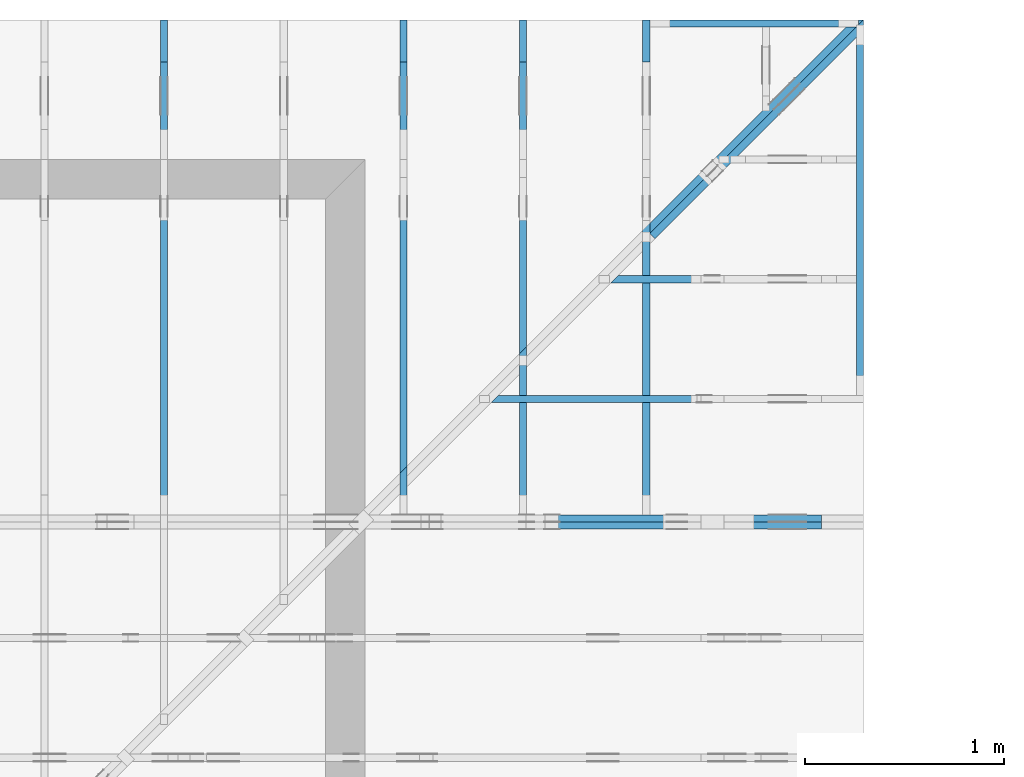
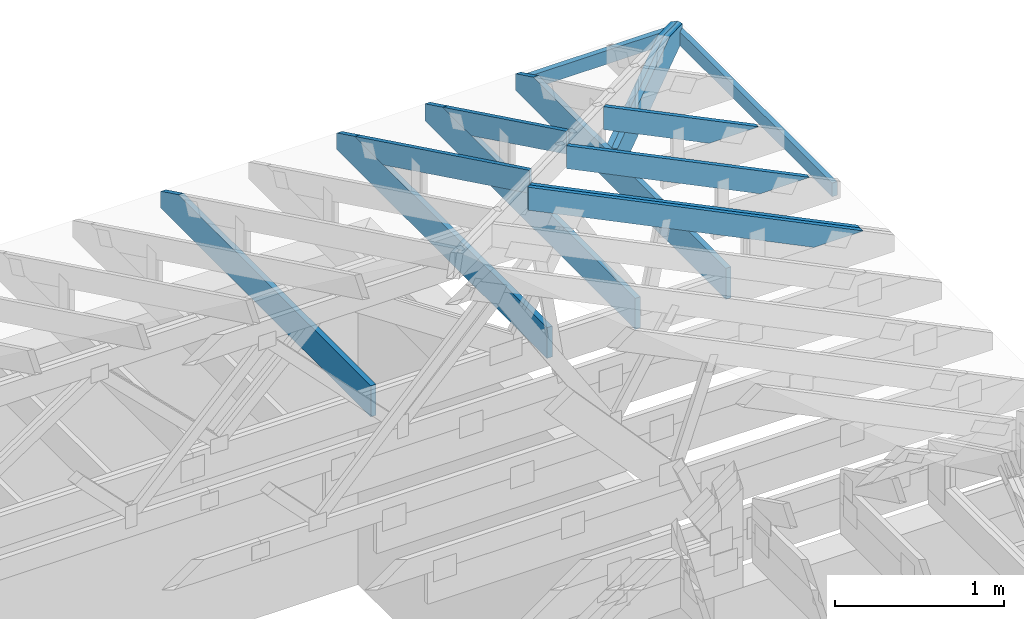
# One storey, part 40 of 159: 14 members, 10 elements without a shape of their own.
"""IFC2X3 building model written with IfcOpenShell, lengths in millimetres."""

from ifc_helpers import new_model, si_unit, frame, origin, origin_with_axes, origin_2d, place, context, project, spatial, faceted_brep, element, aggregate, save


model = new_model("IFC2X3")

# Units and contexts
model_context = context("Model", 3, precision=1e-05, world=origin())
plan_context = context("Plan", 2, precision=1e-05, world=origin_2d())
ifc_project = project(units=[si_unit("LENGTHUNIT", "METRE", prefix="MILLI"), si_unit("AREAUNIT", "SQUARE_METRE"), si_unit("VOLUMEUNIT", "CUBIC_METRE"), si_unit("SOLIDANGLEUNIT", "STERADIAN"), si_unit("PLANEANGLEUNIT", "RADIAN"), si_unit("MASSUNIT", "GRAM"), si_unit("TIMEUNIT", "SECOND"), si_unit("THERMODYNAMICTEMPERATUREUNIT", "DEGREE_CELSIUS"), si_unit("LUMINOUSINTENSITYUNIT", "LUMEN")], contexts=[model_context, plan_context])

# Site, building, storey
site_placement = place(None, origin_with_axes())
site = spatial("IfcSite", under=ifc_project, at=site_placement, CompositionType="ELEMENT")
building_placement = place(site_placement, origin_with_axes())
building = spatial("IfcBuilding", under=site, at=building_placement, Name="Plan 1", CompositionType="ELEMENT")
storey_placement = place(building_placement, origin_with_axes())
storey = spatial("IfcBuildingStorey", under=building, at=storey_placement, Name="Etasje 1", CompositionType="ELEMENT", Elevation=0.0)

# Assembly, members
assembly_1_placement = place(storey_placement, frame((19200.01266310149, 11417.999978540158, 0.0), z_axis=(1.2246063538223773e-16, 1.0, 6.123031769111886e-17), x_axis=(-1.0, 1.2246063538223773e-16, 0.0)))
assembly_1 = element("IfcElementAssembly", 1, at=assembly_1_placement, inside=storey, Name="V9 (1)", AssemblyPlace="FACTORY", PredefinedType="TRUSS")
member_1_placement = place(assembly_1_placement, frame((276.0601842808801, 89.97846073185853, -36.00000021758841), z_axis=(0.0, 0.0, 1.0), x_axis=(0.8987940462991674, 0.4383711467890767, 0.0)))
member_1 = element("IfcMember", 2, at=member_1_placement, Name="V9-O46.2/", context=model_context, shape_type="Brep", body=[
    faceted_brep([(2509.9265675109073, 148.00000083082767, 2.253328602819238e-06), (2469.8729005135738, 147.99999513789197, 35.99999718737763), (2397.6884765625, 3.2118276749315555e-07, 36.000000217588195), (2437.742146505028, -5.684341886080802e-14, -2.2737367544323206e-13), (9.693632841845101e-05, 148.00000032211753, 2.1758840773600238e-07), (9.693632841845101e-05, 148.00000032211753, 36.000000217588415), (2469.8728996707036, 148.0000003221174, 36.000000217588415), (2509.9265686465337, 148.0000003221174, 2.1758840773600238e-07), (5.585594794865756e-05, 148.00000032054504, 2.1758840773600924e-07), (2509.926569527823, 148.00000032054504, 2.1758871510320488e-07), (2437.7421441738193, 3.221430233679712e-07, 2.175887062634543e-07), (303.4451242153232, 3.221430233679712e-07, 2.1758844489608513e-07), (303.44501446892843, 3.2039707775766146e-07, 2.175884077360024e-07), (303.44501446892843, 3.2039707775766146e-07, 36.00000021758841), (4.275579697576859e-05, 148.0000018613371, 36.00000021758841), (4.275579697576859e-05, 148.0000018613371, 2.175884077360024e-07), (2437.7421464196145, 3.211971882968838e-07, 2.175884077360024e-07), (2397.6884774437844, 3.2119719785867186e-07, 36.00000021758841), (303.44502727898976, 3.2119758255224717e-07, 36.00000021758841), (303.44502727898976, 3.2119758034795574e-07, 2.175884077360024e-07), (2469.8729019165044, 148.0000003211826, 36.00000021758841), (0.0, 148.0000003211826, 36.00000021758841), (303.4450683593752, 3.2039704933595203e-07, 36.00000021758841), (2397.6884765625005, 3.2039704933595203e-07, 36.00000021758841)], [[[0, 1, 2, 3]], [[4, 5, 6, 7]], [[8, 9, 10, 11]], [[12, 13, 14, 15]], [[16, 17, 18, 19]], [[20, 21, 22, 23]]]),
])
member_2_placement = place(assembly_1_placement, frame((276.06014875934784, 89.97843985036639, -72.0), z_axis=(0.0, 0.0, 1.0), x_axis=(0.8987940462991674, 0.4383711467890767, 0.0)))
member_2 = element("IfcMember", 3, at=member_2_placement, Name="V9-O46.2/", context=model_context, shape_type="Brep", body=[
    faceted_brep([(2538.248801395678, 148.00000519359992, 10.544184276268652), (2509.926611451075, 147.99999833445304, 35.999996969790345), (2437.742187500001, 3.5177433233002375e-06, 36.00000000000023), (2466.064374499408, 3.2894670312089147e-06, 10.544186846680532), (9.693633353435871e-05, 148.000003518689, 0.0), (9.693633353435871e-05, 148.000003518689, 36.00000000000001), (2509.9266106082086, 148.00000351868886, 36.00000000000001), (2538.2487980319147, 148.00000351868886, 10.544185638427734), (2538.2487980319147, 148.00000351868886, -1.1044052673094165e-29), (2538.2487987942563, 148.00000355018324, 1.0740475886450439e-07), (2538.2487987942563, 148.00000355018324, 10.544185894022071), (2466.064378398536, 9.110662745115405e-06, 10.54418560520537), (2466.064378398536, 9.110662858802243e-06, 4.6991519297989726e-07), (303.4450555493138, 3.516943081649515e-06, 5.4704588450238366e-30), (303.4450555493138, 3.516943081649515e-06, 36.0), (8.383618233409607e-05, 148.0000050578831, 36.0), (8.383618233409607e-05, 148.0000050578831, 1.9992341226455827e-31), (2466.064375670692, 3.5177538410863624e-06, 2.555943297011254e-07), (2466.064375670692, 3.517753841731986e-06, 10.544185894022071), (2437.742188246986, 3.517753848493183e-06, 36.00000025559434), (303.4449909050669, 3.5177542405442695e-06, 36.00000025559434), (303.4449909050669, 3.517754238339978e-06, 2.555943297011254e-07), (2509.926612854004, 148.00000351774383, 36.0), (0.0, 148.00000351774383, 36.0), (303.4450683593751, 3.5169432521797717e-06, 36.0), (2437.7421875, 3.5169432521797717e-06, 36.0), (1.94820292449549e-05, 148.0000035170913, 2.3857816798725143e-21), (2538.248798778904, 148.0000035170913, 3.1083556065666625e-13), (2466.0643734249006, 3.518706989780185e-06, 3.019958100631133e-13), (303.44508784140396, 3.518706989780185e-06, 3.716007826067727e-14)], [[[0, 1, 2, 3]], [[4, 5, 6, 7, 8]], [[9, 10, 11, 12]], [[13, 14, 15, 16]], [[17, 18, 19, 20, 21]], [[22, 23, 24, 25]], [[26, 27, 28, 29]]]),
])
aggregate(assembly_1, [member_1, member_2])

assembly_2_placement = place(storey_placement, frame((19174.556818978774, 13925.455822662876, 2.204291436880279e-15), z_axis=(-0.7071067811865465, 0.7071067811865486, 6.123031769111886e-17), x_axis=(-0.7071067811865486, -0.7071067811865465, 0.0)))
assembly_2 = element("IfcElementAssembly", 4, at=assembly_2_placement, inside=storey, Name="GR3 (58)", AssemblyPlace="FACTORY", PredefinedType="TRUSS")
member_3_placement = place(assembly_2_placement, frame((1514.6091523000334, 223.00000000001435, -36.00000107077109), z_axis=(0.0, 0.0, 1.0), x_axis=(-1.0, 1.2246063538223773e-16, 0.0)))
member_3 = element("IfcMember", 5, at=member_3_placement, Name="GR3-U17.1", context=model_context, shape_type="Brep", body=[
    faceted_brep([(-1.3570674021985078e-14, 1.4076707465682665e-11, 2.1252264003405104e-13), (36.000001068749036, 1.404032445861958e-11, 36.000001070771084), (36.00000106874927, 223.000000000014, 36.00000107077109), (-3.6040238038717733e-16, 223.00000000001404, 3.604023803666417e-16), (1197.9537364203115, 1.4942895894789178e-13, 1.070771091349343e-06), (1197.9537364203115, 1.7561406771667544e-13, 36.00000107077109), (36.00000106874904, 3.890544567905507e-13, 36.00000107077109), (1.0687490430427715e-06, 3.694822223324079e-13, 1.070771091349343e-06), (1514.6091533699246, 223.00000233343388, 1.0506937542231753e-09), (1478.609152300065, 223.00000233343388, 36.00000107080825), (1478.609152300065, 96.79217762640263, 36.00000107080814), (1514.6085005994914, 109.2075972049273, 0.0006527714839421606), (1.070774032996269e-06, 223.00000000001435, 1.070771091349343e-06), (36.00000107077403, 223.00000000001435, 36.00000107077109), (1478.609131930149, 223.00000000001427, 36.00000107077109), (1514.609131930149, 223.00000000001427, 1.070771091349343e-06), (1514.6084997170888, 109.20759731232903, 0.0006536538031554073), (1478.6091537227362, 96.79217811706559, 36.00000134057073), (1197.9537016181357, 6.185791789903305e-07, 36.00000134057072), (1197.9537016181357, 6.185791789903305e-07, 1.0707782109875552e-06), (1478.6091319281243, 223.00000000000034, 36.00000107077109), (36.00000106874927, 223.00000000000034, 36.00000107077109), (36.00000106874904, 1.404032445861958e-11, 36.00000107077109), (1197.9537364203118, 1.404032445861958e-11, 36.00000107077109), (1478.6091319281243, 96.79217529298279, 36.00000107077109), (2.1440658429128234e-05, 223.00000000001435, 1.0707710913493454e-06), (1514.6091523000334, 223.00000000001435, 1.070771276829342e-06), (1514.6084997170667, 109.20759582519531, 1.0707712768292622e-06), (1197.9536957570647, 0.0, 1.0707712380515136e-06), (2.1440658429128234e-05, 0.0, 1.0707710913493454e-06)], [[[0, 1, 2, 3]], [[4, 5, 6, 7]], [[8, 9, 10, 11]], [[12, 13, 14, 15]], [[16, 17, 18, 19]], [[20, 21, 22, 23, 24]], [[25, 26, 27, 28, 29]]]),
])
member_4_placement = place(assembly_2_placement, frame((1514.6091878283771, 223.0000036032329, -72.00000088236348), z_axis=(0.0, 0.0, 1.0), x_axis=(-1.0, 1.2246063538223773e-16, 0.0)))
member_4 = element("IfcMember", 6, at=member_4_placement, Name="GR3-U17.1", context=model_context, shape_type="Brep", body=[
    faceted_brep([(1478.6091869461084, 223.00000509035152, -1.1368683772161603e-13), (1514.6091878283837, 223.00000509035152, 36.000000882368), (1514.6085352454324, 109.20760091554682, 35.99934829941651), (1478.6091869461084, 96.79218133699456, -1.1368683772161603e-13), (5.6969002116602496e-05, 223.00000360321854, 8.823634800592117e-07), (5.6969002116602496e-05, 223.00000360321854, 36.00000088236348), (1514.6091878283771, 223.00000360321846, 36.00000088236348), (1478.6091878283771, 223.00000360321846, 8.823634800592117e-07), (5.6969096476677805e-05, 223.0000036032329, 8.823634800592187e-07), (1478.6091878284715, 223.0000036032329, 8.823636611306324e-07), (1478.6091878284715, 96.79217889618764, 8.823636611306324e-07), (1197.9537312855027, 3.6032188859280723e-06, 8.823636267613868e-07), (5.6969096476677805e-05, 3.6032188859280723e-06, 8.823634800592187e-07), (3.659911749309686e-05, 3.322476146649933e-06, 1.448955373462013e-06), (3.6599117495301154e-05, 3.322476146649933e-06, 36.00000088236348), (3.659911772067366e-05, 223.00000692619702, 36.000002030721966), (3.659911771846937e-05, 223.00000692619702, 2.2173422848936752e-06), (1197.9537353515625, 3.6027671585987974e-06, 8.823634800592117e-07), (1197.9537353515625, 3.602767160803089e-06, 36.00000088236348), (4.049084095856565e-31, 3.6027673808563523e-06, 36.00000088236348), (1.1754943508222875e-38, 3.602767378652061e-06, 8.823634800592117e-07), (1514.608533822824, 109.20760042491952, 35.99934856913106), (1197.953724905109, 0.0, 36.00000088236346), (1197.953724905109, 0.0, 8.823634800592118e-07), (1478.609187828472, 96.79218122965557, 8.823634800592118e-07), (1514.609187828399, 223.00000509035152, 36.00000088236348), (1.473761972192733e-05, 223.00000509035152, 36.00000088236348), (1.473761972192733e-05, 5.0903515216305095e-06, 36.00000088236348), (1197.9537500891822, 5.0903515216305095e-06, 36.00000088236348), (1514.6085352454322, 109.20760091554682, 36.00000088236348)], [[[0, 1, 2, 3]], [[4, 5, 6, 7]], [[8, 9, 10, 11, 12]], [[13, 14, 15, 16]], [[17, 18, 19, 20]], [[21, 22, 23, 24]], [[25, 26, 27, 28, 29]]]),
])
aggregate(assembly_2, [member_3, member_4])

# Assembly, member
assembly_3_placement = place(storey_placement, frame((15675.022261404756, 13899.999978540158, 1.1021457184401395e-15), z_axis=(-1.0, 1.836909530733566e-16, 6.123031769111886e-17), x_axis=(-1.836909530733566e-16, -1.0, 0.0)))
assembly_3 = element("IfcElementAssembly", 7, at=assembly_3_placement, inside=storey, Name="S38 (64)", AssemblyPlace="FACTORY", PredefinedType="TRUSS")
member_5_placement = place(assembly_3_placement, frame((2482.0, 223.00000000093004, -36.0), z_axis=(0.0, 0.0, 1.0), x_axis=(-1.0, 5.665498452323003e-16, 0.0)))
member_5 = element("IfcMember", 8, at=member_5_placement, Name="S38-U12", context=model_context, shape_type="Brep", body=[
    faceted_brep([(2482.0, 223.00000000093144, 36.0), (0.0, 223.00000000093144, 36.0), (0.0, 9.300435976911103e-10, 36.0), (2270.8187103271484, 9.300435976911103e-10, 36.0), (2482.0, 103.00000000093144, 36.0), (0.0, 223.00000000093144, 0.0), (2482.0, 223.00000000093144, 3.0394729701871404e-13), (2482.0, 103.00000000093144, 3.0394729701871404e-13), (2270.8187103271484, 9.300435976911103e-10, 2.7808590210453623e-13), (0.0, 9.300435976911103e-10, 0.0), (1.1389372990643566e-25, 9.300435976911103e-10, -6.97374926519754e-42), (2.204291436994173e-15, 9.300435976911103e-10, 36.0), (2.9513013127233185e-14, 223.00000000093004, 36.0), (2.7308721690352905e-14, 223.00000000093004, -1.672121704838657e-30), (2270.8187043163925, -1.6082071276856806e-13, 9.847103334126301e-30), (2270.8187043163925, -1.5861642133168778e-13, 36.0), (9.029525915557911e-28, 9.300458019825472e-10, 36.0), (0.0, 9.300435976911103e-10, 0.0), (2482.0000000000005, 103.00000000087255, 4.487866375234114e-29), (2482.0000000000005, 103.00000000087255, 36.0), (2270.8187043163925, -6.821210263296962e-13, 36.0), (2270.8187043163925, -6.821210263296962e-13, 3.1532860652502367e-29), (2482.0, 223.00000000093144, 0.0), (2482.0, 223.00000000093144, 36.0), (2482.0, 103.00000000087323, 36.0), (2482.0, 103.00000000087323, 0.0), (0.0, 223.00000000093004, 0.0), (0.0, 223.00000000093004, 36.0), (2482.0, 223.0000000009321, 36.0), (2482.0, 223.0000000009321, 4.1020767071492614e-29)], [[[0, 1, 2, 3, 4]], [[5, 6, 7, 8, 9]], [[10, 11, 12, 13]], [[14, 15, 16, 17]], [[18, 19, 20, 21]], [[22, 23, 24, 25]], [[26, 27, 28, 29]]]),
])
aggregate(assembly_3, [member_5])

# Assembly, members
assembly_4_placement = place(storey_placement, frame((16875.02226140476, 13899.999978540158, 1.1021457184401395e-15), z_axis=(-1.0, 1.836909530733566e-16, 6.123031769111886e-17), x_axis=(-1.836909530733566e-16, -1.0, 0.0)))
assembly_4 = element("IfcElementAssembly", 9, at=assembly_4_placement, inside=storey, Name="S40 (65)", AssemblyPlace="FACTORY", PredefinedType="TRUSS")
member_6_placement = place(assembly_4_placement, frame((276.06016722592847, 89.97845277006275, -36.00000021762676), z_axis=(0.0, 0.0, 1.0), x_axis=(0.8987940462991668, 0.4383711467890777, 0.0)))
member_6 = element("IfcMember", 10, at=member_6_placement, Name="S40-O51", context=model_context, shape_type="Brep", body=[
    faceted_brep([(2295.5059571541397, 147.999994816739, 36.00000324776647), (2223.321533203125, -1.1368683772161603e-13, 36.00000021762639), (2183.267863260632, 3.211325179108826e-07, -4.547473508864641e-13), (2255.4522872116463, 147.99999513787157, 3.030139396287268e-06), (9.6936336831277e-05, 148.00000000095304, 2.1762676283287874e-07), (9.6936336831277e-05, 148.00000000095292, 36.00000021762676), (2295.5059563113364, 148.00000000095278, 36.00000021762676), (2255.4522873355063, 148.0000000009529, 2.1762676283287874e-07), (0.00013801681973291124, 147.99999999934334, 2.1762676283289565e-07), (2255.4522864543196, 147.99999999934334, 2.1762703903699883e-07), (2183.2678611003157, 9.248424248653464e-10, 2.1762703019724822e-07), (303.44508430588246, 9.248424248653464e-10, 2.1762679999295656e-07), (303.4450332880381, 1.1056044968427159e-11, 2.1762676283287874e-07), (303.4450332880381, 1.1056044968427159e-11, 36.00000021762676), (6.157490692970669e-05, 148.00000154095162, 36.00000021762676), (6.157490692970669e-05, 148.0000015409516, 2.1762676283287874e-07), (2223.3215323219515, -1.8504333334278244e-13, 36.00000021762676), (303.4449873695588, 1.6762061898270549e-13, 36.00000021762676), (303.4449873695588, 2.853204142053421e-13, 2.1762676283287874e-07), (2183.2678633461214, -5.99860414918909e-14, 2.1762676283287874e-07), (2295.5059585571285, 148.0000000000001, 36.00000021762676), (0.0, 148.0000000000001, 36.00000021762676), (303.44506835937466, 1.1397105481592007e-11, 36.00000021762676), (2223.3215332031245, 1.1397105481592007e-11, 36.00000021762676)], [[[0, 1, 2, 3]], [[4, 5, 6, 7]], [[8, 9, 10, 11]], [[12, 13, 14, 15]], [[16, 17, 18, 19]], [[20, 21, 22, 23]]]),
])
member_7_placement = place(assembly_4_placement, frame((2482.0, 223.00000000093004, -36.0), z_axis=(0.0, 0.0, 1.0), x_axis=(-1.0, 5.665498452323003e-16, 0.0)))
member_7 = element("IfcMember", 11, at=member_7_placement, Name="S40-U12", context=model_context, shape_type="Brep", body=[
    faceted_brep([(2482.0, 223.00000000093144, 36.0), (0.0, 223.00000000093144, 36.0), (0.0, 9.300435976911103e-10, 36.0), (2270.8187103271484, 9.300435976911103e-10, 36.0), (2482.0, 103.00000000093144, 36.0), (0.0, 223.00000000093144, 0.0), (2482.0, 223.00000000093144, 3.0394729701871404e-13), (2482.0, 103.00000000093144, 3.0394729701871404e-13), (2270.8187103271484, 9.300435976911103e-10, 2.7808590210453623e-13), (0.0, 9.300435976911103e-10, 0.0), (1.1389372990643566e-25, 9.300435976911103e-10, -6.97374926519754e-42), (2.204291436994173e-15, 9.300435976911103e-10, 36.0), (2.9513013127233185e-14, 223.00000000093004, 36.0), (2.7308721690352905e-14, 223.00000000093004, -1.672121704838657e-30), (2270.8187043163925, -1.6082071276856806e-13, 9.847103334126301e-30), (2270.8187043163925, -1.5861642133168778e-13, 36.0), (9.029525915557911e-28, 9.300458019825472e-10, 36.0), (0.0, 9.300435976911103e-10, 0.0), (2482.0000000000005, 103.00000000087255, 4.487866375234114e-29), (2482.0000000000005, 103.00000000087255, 36.0), (2270.8187043163925, -6.821210263296962e-13, 36.0), (2270.8187043163925, -6.821210263296962e-13, 3.1532860652502367e-29), (2482.0, 223.00000000093144, 0.0), (2482.0, 223.00000000093144, 36.0), (2482.0, 103.00000000087323, 36.0), (2482.0, 103.00000000087323, 0.0), (0.0, 223.00000000093004, 0.0), (0.0, 223.00000000093004, 36.0), (2482.0, 223.0000000009321, 36.0), (2482.0, 223.0000000009321, 4.1020767071492614e-29)], [[[0, 1, 2, 3, 4]], [[5, 6, 7, 8, 9]], [[10, 11, 12, 13]], [[14, 15, 16, 17]], [[18, 19, 20, 21]], [[22, 23, 24, 25]], [[26, 27, 28, 29]]]),
])
aggregate(assembly_4, [member_6, member_7])

assembly_5_placement = place(storey_placement, frame((17475.02226140476, 13899.999978540158, 1.1021457184401395e-15), z_axis=(-1.0, 1.836909530733566e-16, 6.123031769111886e-17), x_axis=(-1.836909530733566e-16, -1.0, 0.0)))
assembly_5 = element("IfcElementAssembly", 12, at=assembly_5_placement, inside=storey, Name="S41 (67)", AssemblyPlace="FACTORY", PredefinedType="TRUSS")
member_8_placement = place(assembly_5_placement, frame((276.06017521396706, 89.97845666585107, -36.000000217626834), z_axis=(0.0, 0.0, 1.0), x_axis=(0.898794046299167, 0.4383711467890774, 0.0)))
member_8 = element("IfcMember", 13, at=member_8_placement, Name="S41-O61", context=model_context, shape_type="Brep", body=[
    faceted_brep([(1627.944783981857, 147.9999948174301, 36.00000324776579), (1555.7603600308425, 6.912159733474255e-10, 36.00000021762662), (1515.7066900883492, 3.2182356335397344e-07, -2.2737367544323206e-13), (1587.8911140393639, 147.99999513856272, 3.030139055226755e-06), (8.098980043769188e-05, 147.9999999999703, 2.1762683388715232e-07), (8.098980043769188e-05, 147.99999999997019, 36.00000021762684), (1627.944783138238, 147.9999999999701, 36.00000021762684), (1587.8911141624078, 147.9999999999702, 2.1762683388715232e-07), (0.0, 148.00000000119053, 2.1762683388715232e-07), (1587.89111328125, 148.00000000119053, 2.1762702834130697e-07), (1515.706687927246, 0.0, 2.1762701950155638e-07), (303.445068359375, 0.0, 2.1762687104722818e-07), (303.44502440063553, 2.255262643302558e-10, 2.1762683388715232e-07), (303.44502440063553, 2.255262643302558e-10, 36.000000217626834), (5.2687504208392966e-05, 148.0000015411658, 36.000000217626834), (5.2687504208392966e-05, 148.0000015411658, 2.1762683388715232e-07), (1555.7603591496627, 6.763316512911086e-10, 36.000000217626834), (303.4449714238324, 6.765616902982284e-10, 36.000000217626834), (303.4449714238324, 6.76679390093451e-10, 2.1762683388715232e-07), (1515.7066901738324, 6.764567085829595e-10, 2.1762683388715232e-07), (1627.9447853848462, 148.00000000069167, 36.000000217626834), (0.00010612459209369263, 148.00000000069167, 36.000000217626834), (303.4450524136548, 2.2563995116797742e-10, 36.000000217626834), (1555.7603600308425, 2.2563995116797742e-10, 36.000000217626834)], [[[0, 1, 2, 3]], [[4, 5, 6, 7]], [[8, 9, 10, 11]], [[12, 13, 14, 15]], [[16, 17, 18, 19]], [[20, 21, 22, 23]]]),
])
member_9_placement = place(assembly_5_placement, frame((2482.0, 223.00000000093004, -36.0), z_axis=(0.0, 0.0, 1.0), x_axis=(-1.0, 5.665498452323003e-16, 0.0)))
member_9 = element("IfcMember", 14, at=member_9_placement, Name="S41-U12", context=model_context, shape_type="Brep", body=[
    faceted_brep([(2482.0, 223.00000000093144, 36.0), (0.0, 223.00000000093144, 36.0), (0.0, 9.300435976911103e-10, 36.0), (2270.8187103271484, 9.300435976911103e-10, 36.0), (2482.0, 103.00000000093144, 36.0), (0.0, 223.00000000093144, 0.0), (2482.0, 223.00000000093144, 3.0394729701871404e-13), (2482.0, 103.00000000093144, 3.0394729701871404e-13), (2270.8187103271484, 9.300435976911103e-10, 2.7808590210453623e-13), (0.0, 9.300435976911103e-10, 0.0), (1.1389372990643566e-25, 9.300435976911103e-10, -6.97374926519754e-42), (2.204291436994173e-15, 9.300435976911103e-10, 36.0), (2.9513013127233185e-14, 223.00000000093004, 36.0), (2.7308721690352905e-14, 223.00000000093004, -1.672121704838657e-30), (2270.8187043163925, -1.6082071276856806e-13, 9.847103334126301e-30), (2270.8187043163925, -1.5861642133168778e-13, 36.0), (9.029525915557911e-28, 9.300458019825472e-10, 36.0), (0.0, 9.300435976911103e-10, 0.0), (2482.0000000000005, 103.00000000087255, 4.487866375234114e-29), (2482.0000000000005, 103.00000000087255, 36.0), (2270.8187043163925, -6.821210263296962e-13, 36.0), (2270.8187043163925, -6.821210263296962e-13, 3.1532860652502367e-29), (2482.0, 223.00000000093144, 0.0), (2482.0, 223.00000000093144, 36.0), (2482.0, 103.00000000087323, 36.0), (2482.0, 103.00000000087323, 0.0), (0.0, 223.00000000093004, 0.0), (0.0, 223.00000000093004, 36.0), (2482.0, 223.0000000009321, 36.0), (2482.0, 223.0000000009321, 4.1020767071492614e-29)], [[[0, 1, 2, 3, 4]], [[5, 6, 7, 8, 9]], [[10, 11, 12, 13]], [[14, 15, 16, 17]], [[18, 19, 20, 21]], [[22, 23, 24, 25]], [[26, 27, 28, 29]]]),
])
aggregate(assembly_5, [member_8, member_9])

# Assembly, member
assembly_6_placement = place(storey_placement, frame((19200.01266310149, 12017.999978540158, 1.1021457184401395e-15), z_axis=(1.2246063538223773e-16, 1.0, 6.123031769111886e-17), x_axis=(-1.0, 1.2246063538223773e-16, 0.0)))
assembly_6 = element("IfcElementAssembly", 15, at=assembly_6_placement, inside=storey, Name="S45 (74)", AssemblyPlace="FACTORY", PredefinedType="TRUSS")
member_10_placement = place(assembly_6_placement, frame((276.0601779366198, 89.97845763822609, -36.000000217542414), z_axis=(0.0, 0.0, 1.0), x_axis=(0.8987940462991671, 0.4383711467890776, 0.0)))
member_10 = element("IfcMember", 16, at=member_10_placement, Name="S45-O59/", context=model_context, shape_type="Brep", body=[
    faceted_brep([(1842.3654102844598, 148.0000008307921, 2.253272668895079e-06), (1802.3117432870854, 147.99999513791062, 35.99999718727565), (1730.127319335938, 3.21236484523979e-07, 36.00000021754249), (1770.1809892785072, 0.0, 2.2737367544323206e-13), (9.693474385130685e-05, 148.00000031892233, 2.1754240719928927e-07), (9.693474385130685e-05, 148.00000031892233, 36.000000217542414), (1802.3117424425566, 148.00000031892222, 36.000000217542414), (1842.3654114183867, 148.00000031892222, 2.1754240719928927e-07), (303.44502152727017, 3.197927753717522e-07, 2.175424071992893e-07), (303.44502152727017, 3.197927753717522e-07, 36.00000021754241), (4.981414350169189e-05, 148.00000186074246, 36.00000021754241), (4.981414350169189e-05, 148.00000186074246, 2.175424071992893e-07), (1770.1809891931682, 3.2127667695536797e-07, 2.175424071992893e-07), (1730.1273202173381, 3.2127668651715604e-07, 36.00000021754241), (303.4450272791058, 3.2127694858578614e-07, 36.00000021754241), (303.4450272791058, 3.212769463814947e-07, 2.175424071992893e-07), (1802.3117446899416, 148.0000003212366, 36.00000021754241), (0.0, 148.0000003212366, 36.00000021754241), (303.4450683593753, 3.1979263326320506e-07, 36.00000021754241), (1730.1273193359377, 3.1979263326320506e-07, 36.00000021754241), (5.5854434776847484e-05, 148.00000032075766, 2.1754240719929613e-07), (1842.3654122997475, 148.00000032075766, 2.175426328165283e-07), (1770.1809869457436, 3.1888146168057574e-07, 2.175426239767777e-07), (303.44500214349745, 3.1888146168057574e-07, 2.1754244435935706e-07)], [[[0, 1, 2, 3]], [[4, 5, 6, 7]], [[8, 9, 10, 11]], [[12, 13, 14, 15]], [[16, 17, 18, 19]], [[20, 21, 22, 23]]]),
])
aggregate(assembly_6, [member_10])

assembly_7_placement = place(storey_placement, frame((19164.01266310149, 12617.999978540158, 1.1021457184401395e-15), z_axis=(1.2246063538223773e-16, 1.0, 6.123031769111886e-17), x_axis=(-1.0, 1.2246063538223773e-16, 0.0)))
assembly_7 = element("IfcElementAssembly", 17, at=assembly_7_placement, inside=storey, Name="S44 (75)", AssemblyPlace="FACTORY", PredefinedType="TRUSS")
member_11_placement = place(assembly_7_placement, frame((240.06017159243646, 89.97845454270455, -36.000000217542436), z_axis=(0.0, 0.0, 1.0), x_axis=(0.8987940462991671, 0.438371146789077, 0.0)))
member_11 = element("IfcMember", 18, at=member_11_placement, Name="S44-O68/", context=model_context, shape_type="Brep", body=[
    faceted_brep([(1174.8042530578969, 148.000000830792, 2.2532724983648222e-06), (1134.7505860605224, 147.99999513791053, 35.999997187275596), (1062.566162109375, 3.212365413673979e-07, 36.000000217542436), (1102.6198320519443, 2.842170943040401e-14, -5.684341886080802e-14), (9.69363063632045e-05, 148.00000032212552, 2.1754243562099873e-07), (9.69363063632045e-05, 148.00000032212552, 36.000000217542436), (1134.7505852175564, 148.00000032212543, 36.000000217542436), (1174.8042541933864, 148.00000032212543, 2.1754243562099873e-07), (303.44502858469775, 3.2173944930491416e-07, 2.1754243562099873e-07), (303.44502858469775, 3.2173944930491416e-07, 36.000000217542436), (5.6871566492588954e-05, 148.0000018626797, 36.000000217542436), (5.6871566492588954e-05, 148.00000186267968, 2.1754243562099873e-07), (1102.6198319665723, 3.2120971452275414e-07, 2.1754243562099873e-07), (1062.5661629907427, 3.2120966812930177e-07, 36.000000217542436), (303.44502727907263, 3.212098075729867e-07, 36.000000217542436), (303.44502727907263, 3.212098613239357e-07, 2.1754243562099873e-07), (1134.750587463379, 148.00000032123648, 36.000000217542436), (0.0, 148.00000032123648, 36.000000217542436), (303.44500732421886, 3.2173960562431603e-07, 36.000000217542436), (1062.566162109375, 3.2173960562431603e-07, 36.000000217542436), (5.585603477697987e-05, 148.0000003210713, 2.1754243562100556e-07), (1174.8042550747846, 148.0000003210713, 2.1754257948827425e-07), (1102.6198297207807, 3.22162691190897e-07, 2.1754257064852366e-07), (303.4450021450973, 3.22162691190897e-07, 2.175424727810665e-07)], [[[0, 1, 2, 3]], [[4, 5, 6, 7]], [[8, 9, 10, 11]], [[12, 13, 14, 15]], [[16, 17, 18, 19]], [[20, 21, 22, 23]]]),
])
aggregate(assembly_7, [member_11])

assembly_8_placement = place(storey_placement, frame((19200.01266310149, 12017.999978540158, 0.0), z_axis=(1.0, -6.123031769111886e-17, 6.123031769111886e-17), x_axis=(6.123031769111886e-17, 1.0, 0.0)))
assembly_8 = element("IfcElementAssembly", 19, at=assembly_8_placement, inside=storey, Name="uu5 (1)", AssemblyPlace="FACTORY", PredefinedType="TRUSS")
member_12_placement = place(assembly_8_placement, frame((1856.544189453125, 98.0, -36.0), z_axis=(0.0, 0.0, 1.0), x_axis=(-1.0, 1.2246063538223773e-16, 0.0)))
member_12 = element("IfcMember", 20, at=member_12_placement, Name="uu5-U48", context=model_context, shape_type="Brep", body=[
    faceted_brep([(1856.544189453125, 98.00000000000023, 36.0), (0.0, 98.00000000000023, 36.0), (0.0, 0.0, 36.0), (1856.544189453125, 0.0, 36.0), (0.0, 98.00000000000023, 0.0), (1856.544189453125, 98.00000000000023, 2.2735358105563122e-13), (1856.544189453125, 0.0, 2.2735358105563122e-13), (0.0, 0.0, 0.0), (3.357584682817105e-05, 0.0, 0.0), (3.3575846830375343e-05, -2.6993892992798474e-31, 36.0), (3.3575846842376486e-05, 98.0, 36.0), (3.3575846840172194e-05, 98.0, -7.348336802244504e-31), (1856.544189453125, -3.4103037569552983e-13, 3.480356062814536e-29), (1856.544189453125, -3.3882608425864955e-13, 36.0), (3.357584682817105e-05, 2.2042811572179548e-15, 36.0), (3.357584682817105e-05, -1.0279662324207141e-20, 6.294269898686286e-37), (1856.544189453125, 98.00000000000023, 0.0), (1856.544189453125, 98.00000000000023, 36.0), (1856.544189453125, 2.2737367544323206e-13, 36.0), (1856.544189453125, 2.2737367544323206e-13, 0.0), (3.357584682817105e-05, 98.0, 0.0), (3.357584682817105e-05, 98.0, 36.0), (1856.544189453125, 98.0000000000003, 36.0), (1856.544189453125, 98.0000000000003, 3.944304526105059e-30)], [[[0, 1, 2, 3]], [[4, 5, 6, 7]], [[8, 9, 10, 11]], [[12, 13, 14, 15]], [[16, 17, 18, 19]], [[20, 21, 22, 23]]]),
])
aggregate(assembly_8, [member_12])

assembly_9_placement = place(storey_placement, frame((18093.02226140476, 13899.9999785399, 1.1021457184401395e-15), z_axis=(-1.0, -1.4305706115156844e-11, 6.123031769111886e-17), x_axis=(1.4305706115156844e-11, -1.0, 0.0)))
assembly_9 = element("IfcElementAssembly", 21, at=assembly_9_placement, inside=storey, Name="S42 (81)", AssemblyPlace="FACTORY", PredefinedType="TRUSS")
member_13_placement = place(assembly_9_placement, frame((2482.0000000002547, 223.00000000093004, -36.0), z_axis=(0.0, 0.0, 1.0), x_axis=(-1.0, 5.665498452323003e-16, 0.0)))
member_13 = element("IfcMember", 22, at=member_13_placement, Name="S42-U12", context=model_context, shape_type="Brep", body=[
    faceted_brep([(2482.0000000002547, 223.00000000093144, 36.0), (2.546585164964199e-10, 223.00000000093144, 36.0), (2.546585164964199e-10, 9.300435976911103e-10, 36.0), (2270.818710327403, 9.300435976911103e-10, 36.0), (2482.000000000513, 103.00000000093144, 36.0), (2.546585164964199e-10, 223.00000000093144, 3.118564373564965e-26), (2482.0000000002547, 223.00000000093144, 3.0394729701874524e-13), (2482.000000000513, 103.00000000093144, 3.0394729701877684e-13), (2270.818710327403, 9.300435976911103e-10, 2.7808590210456744e-13), (2.546585164964199e-10, 9.300435976911103e-10, 3.118564373564965e-26), (1.1389372990643566e-25, 9.300435976911103e-10, -6.97374926519754e-42), (2.204291436994173e-15, 9.300435976911103e-10, 36.0), (2.9513013127233185e-14, 223.00000000093004, 36.0), (2.7308721690352905e-14, 223.00000000093004, -1.672121704838657e-30), (2270.818704316647, -1.6082071287279282e-13, 9.847103340520348e-30), (2270.818704316647, -1.5861642143591254e-13, 36.0), (9.029525915557911e-28, 9.300458019825472e-10, 36.0), (0.0, 9.300435976911103e-10, 0.0), (2482.000000000513, 103.00000000078614, -1.8230208665335993e-29), (2482.000000000513, 103.00000000078614, 36.0), (2270.818704316647, 2.2737367544323206e-13, 36.0), (2270.818704316647, 2.2737367544323206e-13, -1.895423728163918e-29), (2482.000000000735, 223.00000000093144, 2.938349099767225e-26), (2482.000000000735, 223.00000000093144, 36.0), (2482.000000000735, 103.00000000078592, 36.0), (2482.000000000735, 103.00000000078592, 1.358102934428494e-26), (0.0, 223.00000000093004, 0.0), (0.0, 223.00000000093004, 36.0), (2482.0000000002547, 223.0000000009321, 36.0), (2482.0000000002547, 223.0000000009321, 4.1020767071492614e-29)], [[[0, 1, 2, 3, 4]], [[5, 6, 7, 8, 9]], [[10, 11, 12, 13]], [[14, 15, 16, 17]], [[18, 19, 20, 21]], [[22, 23, 24, 25]], [[26, 27, 28, 29]]]),
])
aggregate(assembly_9, [member_13])

assembly_10_placement = place(storey_placement, frame((18129.02226140476, 13863.999978546979, 2.204291436880279e-15), z_axis=(0.0, -1.0, 6.123031769111886e-17), x_axis=(1.0, 0.0, 0.0)))
assembly_10 = element("IfcElementAssembly", 23, at=assembly_10_placement, inside=storey, Name="uu7 (1)", AssemblyPlace="FACTORY", PredefinedType="TRUSS")
member_14_placement = place(assembly_10_placement, frame((1045.5345575463725, 98.0, -36.0), z_axis=(0.0, 0.0, 1.0), x_axis=(-1.0, 1.010639055082363e-15, 0.0)))
member_14 = element("IfcMember", 24, at=member_14_placement, Name="uu7-U52", context=model_context, shape_type="Brep", body=[
    faceted_brep([(1045.5345575463725, 98.00000000000105, 36.0), (1.1647935025393963e-05, 98.00000000000105, 36.0), (1.1647935025393963e-05, 0.0, 36.0), (1045.5345575463725, 0.0, 36.0), (1.1647935025393963e-05, 98.00000000000105, 1.426413524100766e-21), (1045.5345575463725, 98.00000000000105, 1.2803682623121557e-13), (1045.5345575463725, 0.0, 1.2803682623121557e-13), (1.1647935025393963e-05, 0.0, 1.426413524100766e-21), (0.0, 0.0, 0.0), (2.204291436880279e-15, -2.6993892992798474e-31, 36.0), (1.4205433704339576e-14, 98.0, 36.0), (1.2001142267459297e-14, 98.0, -7.3483375369284735e-31), (1045.5345575463725, 7.365659917165834e-13, 1.9289831343406902e-29), (1045.5345575463725, 7.387702831534637e-13, 36.0), (-1.5528956900748675e-30, 2.204291436880279e-15, 36.0), (0.0, 0.0, 0.0), (1045.5345575463725, 98.00000000000105, 0.0), (1045.5345575463725, 98.00000000000105, 36.0), (1045.5345575463725, 1.0516032489249483e-12, 36.0), (1045.5345575463725, 1.0516032489249483e-12, 0.0), (0.0, 98.0, 0.0), (0.0, 98.0, 36.0), (1045.5345575463725, 98.0000000000011, 36.0), (1045.5345575463725, 98.0000000000011, 2.3665827156630354e-30)], [[[0, 1, 2, 3]], [[4, 5, 6, 7]], [[8, 9, 10, 11]], [[12, 13, 14, 15]], [[16, 17, 18, 19]], [[20, 21, 22, 23]]]),
])
aggregate(assembly_10, [member_14])

save(model, "model.ifc")
